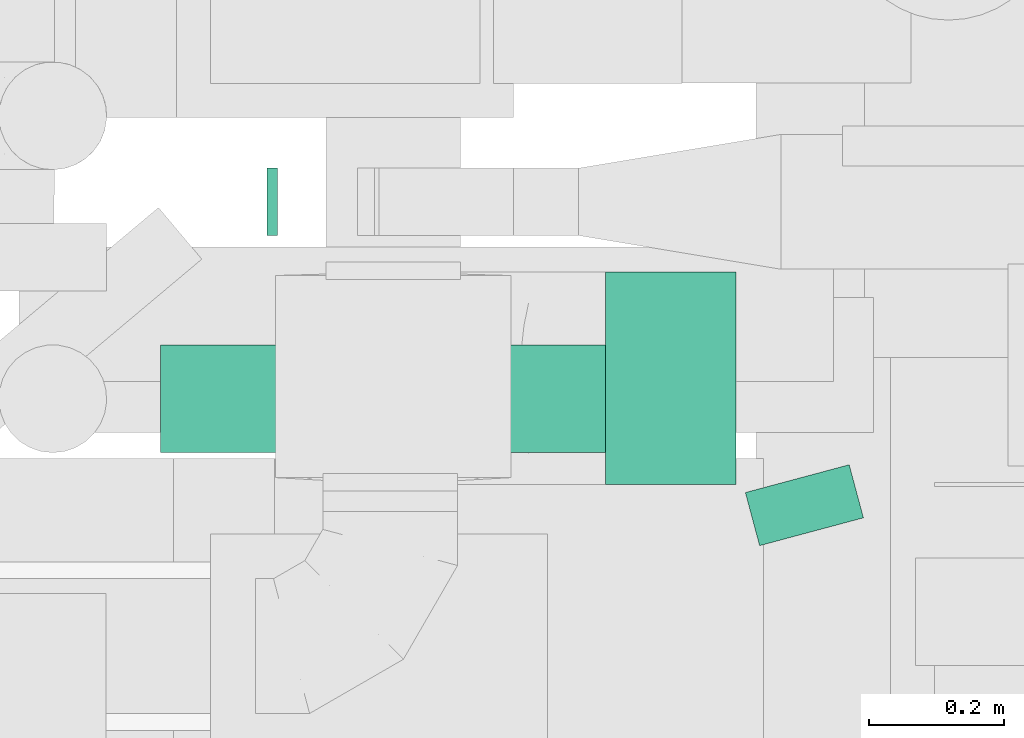
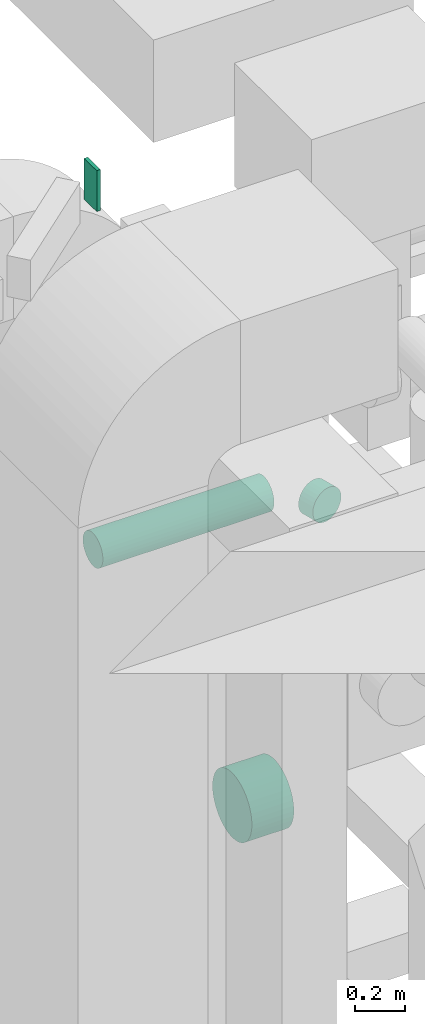
# One storey, part 196 of 337: 4 flow segments.
"""IFC2X3 building model written with IfcOpenShell, lengths in millimetres."""

from ifc_helpers import new_model, entity, si_unit, converted_unit, derived_unit, direction, frame, origin, origin_2d_with_axis, place, context, subcontext, project, spatial, rectangle, circle, extrude, type_object, element, save


model = new_model("IFC2X3")

# Units and contexts
model_context = context("Model", 3, precision=0.01, world=origin(), true_north=direction((6.12303176911189e-17, 1.0)))
body_context = subcontext(model_context, "Body", "Model", "MODEL_VIEW")
ifc_project = project(units=[si_unit("LENGTHUNIT", "METRE", prefix="MILLI"), si_unit("AREAUNIT", "SQUARE_METRE"), si_unit("VOLUMEUNIT", "CUBIC_METRE"), converted_unit("PLANEANGLEUNIT", "DEGREE", entity("IfcRatioMeasure", 0.0174532925199433), si_unit("PLANEANGLEUNIT", "RADIAN"), dimensions=[0, 0, 0, 0, 0, 0, 0]), si_unit("MASSUNIT", "GRAM", prefix="KILO"), derived_unit("MASSDENSITYUNIT", [(si_unit("MASSUNIT", "GRAM", prefix="KILO"), 1), (si_unit("LENGTHUNIT", "METRE"), -3)]), derived_unit("MOMENTOFINERTIAUNIT", [(si_unit("LENGTHUNIT", "METRE"), 4)]), si_unit("TIMEUNIT", "SECOND"), si_unit("FREQUENCYUNIT", "HERTZ"), si_unit("THERMODYNAMICTEMPERATUREUNIT", "DEGREE_CELSIUS"), derived_unit("THERMALTRANSMITTANCEUNIT", [(si_unit("MASSUNIT", "GRAM", prefix="KILO"), 1), (si_unit("THERMODYNAMICTEMPERATUREUNIT", "KELVIN"), -1), (si_unit("TIMEUNIT", "SECOND"), -3)]), derived_unit("VOLUMETRICFLOWRATEUNIT", [(si_unit("LENGTHUNIT", "METRE"), 3), (si_unit("TIMEUNIT", "SECOND"), -1)]), derived_unit("MASSFLOWRATEUNIT", [(si_unit("MASSUNIT", "GRAM", prefix="KILO"), 1), (si_unit("TIMEUNIT", "SECOND"), -1)]), derived_unit("ROTATIONALFREQUENCYUNIT", [(si_unit("TIMEUNIT", "SECOND"), -1)]), si_unit("ELECTRICCURRENTUNIT", "AMPERE"), si_unit("ELECTRICVOLTAGEUNIT", "VOLT"), si_unit("POWERUNIT", "WATT"), si_unit("FORCEUNIT", "NEWTON", prefix="KILO"), si_unit("ILLUMINANCEUNIT", "LUX"), si_unit("LUMINOUSFLUXUNIT", "LUMEN"), si_unit("LUMINOUSINTENSITYUNIT", "CANDELA"), derived_unit("USERDEFINED", [(si_unit("MASSUNIT", "GRAM", prefix="KILO"), -1), (si_unit("LENGTHUNIT", "METRE"), -2), (si_unit("TIMEUNIT", "SECOND"), 3), (si_unit("LUMINOUSFLUXUNIT", "LUMEN"), 1)]), derived_unit("LINEARVELOCITYUNIT", [(si_unit("LENGTHUNIT", "METRE"), 1), (si_unit("TIMEUNIT", "SECOND"), -1)]), si_unit("PRESSUREUNIT", "PASCAL"), derived_unit("USERDEFINED", [(si_unit("LENGTHUNIT", "METRE"), -2), (si_unit("MASSUNIT", "GRAM", prefix="KILO"), 1), (si_unit("TIMEUNIT", "SECOND"), -2)]), derived_unit("LINEARFORCEUNIT", [(si_unit("MASSUNIT", "GRAM", prefix="KILO"), 1), (si_unit("LENGTHUNIT", "METRE"), 1), (si_unit("TIMEUNIT", "SECOND"), -2), (si_unit("LENGTHUNIT", "METRE"), -1)]), derived_unit("PLANARFORCEUNIT", [(si_unit("MASSUNIT", "GRAM", prefix="KILO"), 1), (si_unit("LENGTHUNIT", "METRE"), 1), (si_unit("TIMEUNIT", "SECOND"), -2), (si_unit("LENGTHUNIT", "METRE"), -2)])], contexts=[model_context])

# Site, building, storey
site_placement = place(None, origin())
site = spatial("IfcSite", under=ifc_project, at=site_placement, CompositionType="ELEMENT")
building_placement = place(site_placement, origin())
building = spatial("IfcBuilding", under=site, at=building_placement, CompositionType="ELEMENT")
storey_placement = place(building_placement, origin())
storey = spatial("IfcBuildingStorey", under=building, at=storey_placement, CompositionType="ELEMENT", Elevation=0.0)

# Flow segments
duct_segment_type_1 = type_object("IfcDuctSegmentType", PredefinedType="NOTDEFINED")
flow_segment_1_placement = place(storey_placement, frame((52384.01, 12416.31, 31750.0)))
element("IfcFlowSegment", 1, at=flow_segment_1_placement, inside=storey, type_object=duct_segment_type_1, context=body_context, shape_type="SweptSolid", body=[
    extrude(rectangle(XDim=16.209675230296, YDim=99.9999999999989, at=origin_2d_with_axis()), frame((8.1, 50.0, 0.0)), (0.0, 0.0, 1.0), 199.999999999998),
])
duct_segment_type_2 = type_object("IfcDuctSegmentType", PredefinedType="NOTDEFINED")
flow_segment_2_placement = place(storey_placement, frame((52886.74, 12045.35, 28648.4)))
element("IfcFlowSegment", 2, at=flow_segment_2_placement, inside=storey, type_object=duct_segment_type_2, context=body_context, shape_type="SweptSolid", body=[
    extrude(circle(Radius=157.5, at=origin_2d_with_axis()), frame((0.0, 159.1, 159.1), z_axis=(1.0, 0.0, 0.0), x_axis=(0.0, 1.0, 0.0)), (0.0, 0.0, 1.0), 193.933615001271),
])
flow_segment_3_placement = place(storey_placement, frame((53092.25, 11954.29, 30223.4)))
element("IfcFlowSegment", 3, at=flow_segment_3_placement, inside=storey, type_object=duct_segment_type_2, context=body_context, shape_type="SweptSolid", body=[
    extrude(circle(Radius=80.0, at=origin_2d_with_axis()), frame((78.87, 101.12, 81.6), z_axis=(0.258819045102328, -0.96592582628912, 0.0), x_axis=(0.96592582628912, 0.258819045102328, 0.0)), (0.0, 0.0, 1.0), 81.6026364204279),
])
flow_segment_4_placement = place(storey_placement, frame((52226.37, 12092.4, 30223.4)))
element("IfcFlowSegment", 4, at=flow_segment_4_placement, inside=storey, type_object=duct_segment_type_2, context=body_context, shape_type="SweptSolid", body=[
    extrude(circle(Radius=80.0, at=origin_2d_with_axis()), frame((0.0, 81.6, 81.6), z_axis=(1.0, 0.0, 0.0), x_axis=(0.0, 1.0, 0.0)), (0.0, 0.0, 1.0), 790.201450758721),
])

save(model, "model.ifc")
